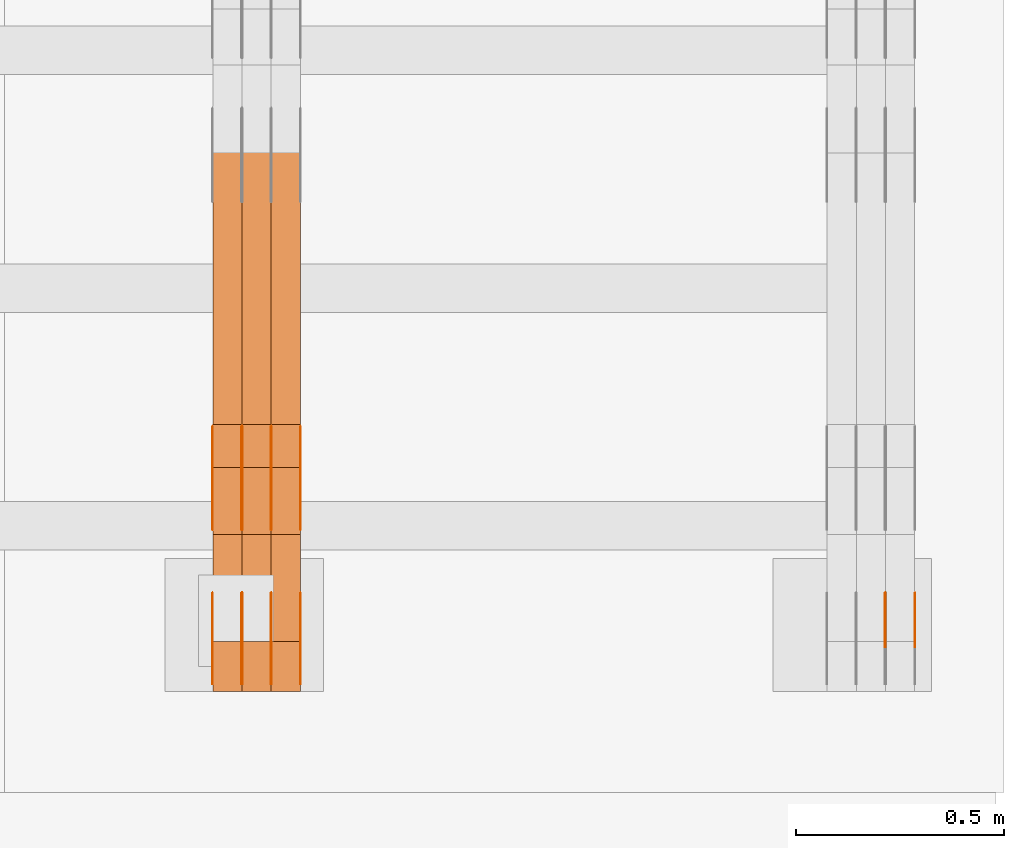
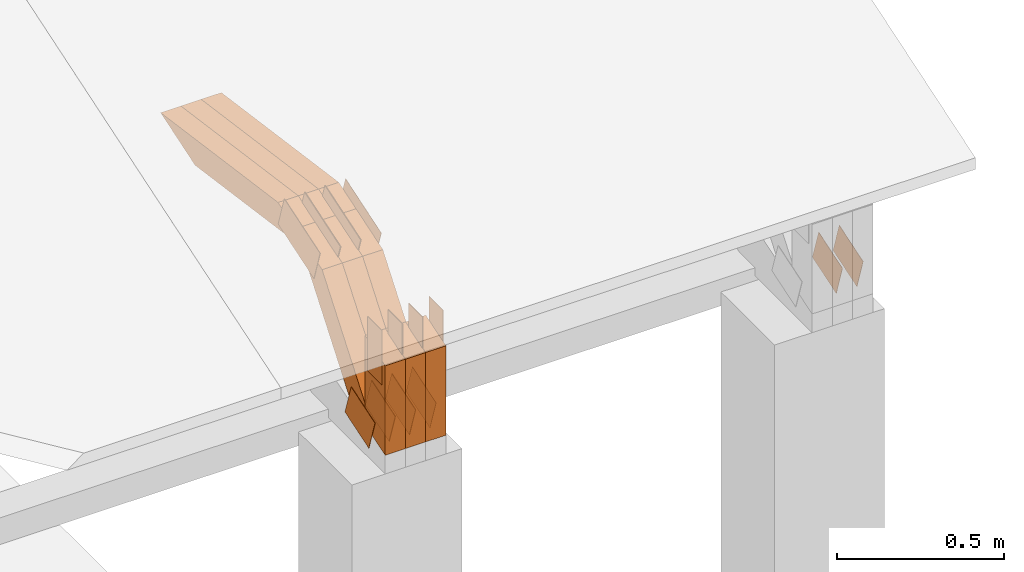
# One storey, part 306 of 385: 29 proxies.
"""IFC2X3 building model written with IfcOpenShell, lengths in millimetres."""

from ifc_helpers import new_model, entity, si_unit, converted_unit, derived_unit, direction, frame, frame_2d, origin, place, context, subcontext, project, spatial, polyline, rectangle, outline, extrude, source, transform, mapped, material, type_object, type_shapes, element, save


model = new_model("IFC2X3")

# Units and contexts
model_context = context("Model", 3, precision=0.01, world=origin(), true_north=direction((6.12303176911189e-17, 1.0)))
body_context = subcontext(model_context, "Body", "Model", "MODEL_VIEW")
ifc_project = project(units=[si_unit("LENGTHUNIT", "METRE", prefix="MILLI"), si_unit("AREAUNIT", "SQUARE_METRE"), si_unit("VOLUMEUNIT", "CUBIC_METRE"), converted_unit("PLANEANGLEUNIT", "DEGREE", entity("IfcRatioMeasure", 0.0174532925199433), si_unit("PLANEANGLEUNIT", "RADIAN"), dimensions=[0, 0, 0, 0, 0, 0, 0]), si_unit("MASSUNIT", "GRAM", prefix="KILO"), derived_unit("MASSDENSITYUNIT", [(si_unit("MASSUNIT", "GRAM", prefix="KILO"), 1), (si_unit("LENGTHUNIT", "METRE"), -3)]), si_unit("TIMEUNIT", "SECOND"), si_unit("FREQUENCYUNIT", "HERTZ"), si_unit("THERMODYNAMICTEMPERATUREUNIT", "DEGREE_CELSIUS"), derived_unit("THERMALTRANSMITTANCEUNIT", [(si_unit("MASSUNIT", "GRAM", prefix="KILO"), 1), (si_unit("THERMODYNAMICTEMPERATUREUNIT", "KELVIN"), -1), (si_unit("TIMEUNIT", "SECOND"), -3)]), derived_unit("VOLUMETRICFLOWRATEUNIT", [(si_unit("LENGTHUNIT", "METRE"), 3), (si_unit("TIMEUNIT", "SECOND"), -1)]), si_unit("ELECTRICCURRENTUNIT", "AMPERE"), si_unit("ELECTRICVOLTAGEUNIT", "VOLT"), si_unit("POWERUNIT", "WATT"), si_unit("FORCEUNIT", "NEWTON", prefix="KILO"), si_unit("ILLUMINANCEUNIT", "LUX"), si_unit("LUMINOUSFLUXUNIT", "LUMEN"), si_unit("LUMINOUSINTENSITYUNIT", "CANDELA"), derived_unit("USERDEFINED", [(si_unit("MASSUNIT", "GRAM", prefix="KILO"), -1), (si_unit("LENGTHUNIT", "METRE"), -2), (si_unit("TIMEUNIT", "SECOND"), 3), (si_unit("LUMINOUSFLUXUNIT", "LUMEN"), 1)]), derived_unit("LINEARVELOCITYUNIT", [(si_unit("LENGTHUNIT", "METRE"), 1), (si_unit("TIMEUNIT", "SECOND"), -1)]), si_unit("PRESSUREUNIT", "PASCAL"), derived_unit("USERDEFINED", [(si_unit("LENGTHUNIT", "METRE"), -2), (si_unit("MASSUNIT", "GRAM", prefix="KILO"), 1), (si_unit("TIMEUNIT", "SECOND"), -2)])], contexts=[model_context])

# Site, building, storey
site_placement = place(None, origin())
site = spatial("IfcSite", under=ifc_project, at=site_placement, CompositionType="ELEMENT")
building_placement = place(site_placement, origin())
building = spatial("IfcBuilding", under=site, at=building_placement, CompositionType="ELEMENT")
storey_placement = place(building_placement, origin())
storey = spatial("IfcBuildingStorey", under=building, at=storey_placement, Name="Default", CompositionType="ELEMENT", Elevation=0.0)

# Proxies
ifc_material_1 = material(Name="IfcSurfaceStyle #615484")
building_element_proxy_type_1 = type_object("IfcBuildingElementProxyType", PredefinedType="NOTDEFINED", material=ifc_material_1)
shared_shape_1 = source(origin(), body_context, "Body", "SweptSolid", [
    extrude(outline(polyline([(-74.999865408764, -60.0000379172698), (74.9998729365771, -60.0000379172698), (74.9998642299588, 60.0000379172698), (-74.9998717577719, 60.0000379172698), (-74.999865408764, -60.0000379172698)])), frame((75.0005044383734, 60.0001679035349, 0.0), z_axis=(0.0, 0.0, 1.0), x_axis=(-1.0, 0.0, 0.0)), (0.0, 0.0, 1.0), 1.3),
])
type_shapes(building_element_proxy_type_1, [shared_shape_1])
proxy_1_placement = place(building_placement, frame((49861.3, 2998.66143710397, 150.423871180894), z_axis=(-1.0, 0.0, 0.0), x_axis=(0.0, 0.951056516295124, 0.309016994375039)))
element("IfcBuildingElementProxy", 1, at=proxy_1_placement, inside=storey, type_object=building_element_proxy_type_1, material=ifc_material_1, context=body_context, shape_type="MappedRepresentation", body=[
    mapped(shared_shape_1, transform((0.0, 0.0, 0.0), scale=1.0)),
])
ifc_material_2 = material(Name="IfcSurfaceStyle #615427")
building_element_proxy_type_2 = type_object("IfcBuildingElementProxyType", PredefinedType="NOTDEFINED", material=ifc_material_2)
shared_shape_2 = source(origin(), body_context, "Body", "SweptSolid", [
    extrude(outline(polyline([(-74.999865408764, -60.0000379172698), (74.9998729365771, -60.0000379172698), (74.9998642299588, 60.0000379172698), (-74.9998717577719, 60.0000379172698), (-74.999865408764, -60.0000379172698)])), frame((75.0005044383734, 60.0001679035349, 0.0), z_axis=(0.0, 0.0, 1.0), x_axis=(-1.0, 0.0, 0.0)), (0.0, 0.0, 1.0), 1.3),
])
type_shapes(building_element_proxy_type_2, [shared_shape_2])
proxy_2_placement = place(building_placement, frame((49790.0, 2998.66143710397, 150.423871180894), z_axis=(-1.0, 0.0, 0.0), x_axis=(0.0, 0.951056516295124, 0.309016994375039)))
element("IfcBuildingElementProxy", 2, at=proxy_2_placement, inside=storey, type_object=building_element_proxy_type_2, material=ifc_material_2, context=body_context, shape_type="MappedRepresentation", body=[
    mapped(shared_shape_2, transform((0.0, 0.0, 0.0), scale=1.0)),
])
ifc_material_3 = material(Name="IfcSurfaceStyle #581052")
building_element_proxy_type_3 = type_object("IfcBuildingElementProxyType", PredefinedType="NOTDEFINED", material=ifc_material_3)
shared_shape_3 = source(origin(), body_context, "Body", "SweptSolid", [
    extrude(outline(polyline([(-74.999865408764, -60.0000379172698), (74.9998729365771, -60.0000379172698), (74.9998642299588, 60.0000379172698), (-74.9998717577719, 60.0000379172698), (-74.999865408764, -60.0000379172698)])), frame((75.0005044383734, 60.0001679035349, 0.0), z_axis=(0.0, 0.0, 1.0), x_axis=(-1.0, 0.0, 0.0)), (0.0, 0.0, 1.0), 1.3),
])
type_shapes(building_element_proxy_type_3, [shared_shape_3])
proxy_3_placement = place(building_placement, frame((48386.3, 2998.66143710398, 150.423871180894), z_axis=(-1.0, 0.0, 0.0), x_axis=(0.0, 0.951056516295124, 0.309016994375039)))
element("IfcBuildingElementProxy", 3, at=proxy_3_placement, inside=storey, type_object=building_element_proxy_type_3, material=ifc_material_3, context=body_context, shape_type="MappedRepresentation", body=[
    mapped(shared_shape_3, transform((0.0, 0.0, 0.0), scale=1.0)),
])
ifc_material_4 = material(Name="IfcSurfaceStyle #580995")
building_element_proxy_type_4 = type_object("IfcBuildingElementProxyType", PredefinedType="NOTDEFINED", material=ifc_material_4)
shared_shape_4 = source(origin(), body_context, "Body", "SweptSolid", [
    extrude(outline(polyline([(-74.999865408764, -60.0000379172698), (74.9998729365771, -60.0000379172698), (74.9998642299588, 60.0000379172698), (-74.9998717577719, 60.0000379172698), (-74.999865408764, -60.0000379172698)])), frame((75.0005044383734, 60.0001679035349, 0.0), z_axis=(0.0, 0.0, 1.0), x_axis=(-1.0, 0.0, 0.0)), (0.0, 0.0, 1.0), 1.3),
])
type_shapes(building_element_proxy_type_4, [shared_shape_4])
proxy_4_placement = place(building_placement, frame((48315.0, 2998.66143710398, 150.423871180894), z_axis=(-1.0, 0.0, 0.0), x_axis=(0.0, 0.951056516295124, 0.309016994375039)))
element("IfcBuildingElementProxy", 4, at=proxy_4_placement, inside=storey, type_object=building_element_proxy_type_4, material=ifc_material_4, context=body_context, shape_type="MappedRepresentation", body=[
    mapped(shared_shape_4, transform((0.0, 0.0, 0.0), scale=1.0)),
])
ifc_material_5 = material(Name="IfcSurfaceStyle #580938")
building_element_proxy_type_5 = type_object("IfcBuildingElementProxyType", PredefinedType="NOTDEFINED", material=ifc_material_5)
shared_shape_5 = source(origin(), body_context, "Body", "SweptSolid", [
    extrude(outline(polyline([(-74.999865408764, -60.0000379172698), (74.9998729365771, -60.0000379172698), (74.9998642299588, 60.0000379172698), (-74.9998717577719, 60.0000379172698), (-74.999865408764, -60.0000379172698)])), frame((75.0005044383734, 60.0001679035349, 0.0), z_axis=(0.0, 0.0, 1.0), x_axis=(-1.0, 0.0, 0.0)), (0.0, 0.0, 1.0), 1.3),
])
type_shapes(building_element_proxy_type_5, [shared_shape_5])
proxy_5_placement = place(building_placement, frame((48316.3, 2998.66143710398, 150.423871180894), z_axis=(-1.0, 0.0, 0.0), x_axis=(0.0, 0.951056516295124, 0.309016994375039)))
element("IfcBuildingElementProxy", 5, at=proxy_5_placement, inside=storey, type_object=building_element_proxy_type_5, material=ifc_material_5, context=body_context, shape_type="MappedRepresentation", body=[
    mapped(shared_shape_5, transform((0.0, 0.0, 0.0), scale=1.0)),
])
ifc_material_6 = material(Name="IfcSurfaceStyle #580881")
building_element_proxy_type_6 = type_object("IfcBuildingElementProxyType", PredefinedType="NOTDEFINED", material=ifc_material_6)
shared_shape_6 = source(origin(), body_context, "Body", "SweptSolid", [
    extrude(outline(polyline([(-74.999865408764, -60.0000379172698), (74.9998729365771, -60.0000379172698), (74.9998642299588, 60.0000379172698), (-74.9998717577719, 60.0000379172698), (-74.999865408764, -60.0000379172698)])), frame((75.0005044383734, 60.0001679035349, 0.0), z_axis=(0.0, 0.0, 1.0), x_axis=(-1.0, 0.0, 0.0)), (0.0, 0.0, 1.0), 1.29999999999999),
])
type_shapes(building_element_proxy_type_6, [shared_shape_6])
proxy_6_placement = place(building_placement, frame((48245.0, 2998.66143710398, 150.423871180894), z_axis=(-1.0, 0.0, 0.0), x_axis=(0.0, 0.951056516295124, 0.309016994375039)))
element("IfcBuildingElementProxy", 6, at=proxy_6_placement, inside=storey, type_object=building_element_proxy_type_6, material=ifc_material_6, context=body_context, shape_type="MappedRepresentation", body=[
    mapped(shared_shape_6, transform((0.0, 0.0, 0.0), scale=1.0)),
])
ifc_material_7 = material(Name="IfcSurfaceStyle #580824")
building_element_proxy_type_7 = type_object("IfcBuildingElementProxyType", PredefinedType="NOTDEFINED", material=ifc_material_7)
shared_shape_7 = source(origin(), body_context, "Body", "SweptSolid", [
    extrude(outline(polyline([(-74.999865408764, -60.0000379172698), (74.9998729365771, -60.0000379172698), (74.9998642299588, 60.0000379172698), (-74.9998717577719, 60.0000379172698), (-74.999865408764, -60.0000379172698)])), frame((75.0005044383734, 60.0001679035349, 0.0), z_axis=(0.0, 0.0, 1.0), x_axis=(-1.0, 0.0, 0.0)), (0.0, 0.0, 1.0), 1.29999999999999),
])
type_shapes(building_element_proxy_type_7, [shared_shape_7])
proxy_7_placement = place(building_placement, frame((48246.3, 2998.66143710398, 150.423871180894), z_axis=(-1.0, 0.0, 0.0), x_axis=(0.0, 0.951056516295124, 0.309016994375039)))
element("IfcBuildingElementProxy", 7, at=proxy_7_placement, inside=storey, type_object=building_element_proxy_type_7, material=ifc_material_7, context=body_context, shape_type="MappedRepresentation", body=[
    mapped(shared_shape_7, transform((0.0, 0.0, 0.0), scale=1.0)),
])
ifc_material_8 = material(Name="IfcSurfaceStyle #580767")
building_element_proxy_type_8 = type_object("IfcBuildingElementProxyType", PredefinedType="NOTDEFINED", material=ifc_material_8)
shared_shape_8 = source(origin(), body_context, "Body", "SweptSolid", [
    extrude(outline(polyline([(-74.999865408764, -60.0000379172698), (74.9998729365771, -60.0000379172698), (74.9998642299588, 60.0000379172698), (-74.9998717577719, 60.0000379172698), (-74.999865408764, -60.0000379172698)])), frame((75.0005044383734, 60.0001679035349, 0.0), z_axis=(0.0, 0.0, 1.0), x_axis=(-1.0, 0.0, 0.0)), (0.0, 0.0, 1.0), 1.29999999999999),
])
type_shapes(building_element_proxy_type_8, [shared_shape_8])
proxy_8_placement = place(building_placement, frame((48175.0, 2998.66143710398, 150.423871180894), z_axis=(-1.0, 0.0, 0.0), x_axis=(0.0, 0.951056516295124, 0.309016994375039)))
element("IfcBuildingElementProxy", 8, at=proxy_8_placement, inside=storey, type_object=building_element_proxy_type_8, material=ifc_material_8, context=body_context, shape_type="MappedRepresentation", body=[
    mapped(shared_shape_8, transform((0.0, 0.0, 0.0), scale=1.0)),
])
ifc_material_9 = material(Name="IfcSurfaceStyle #572502")
building_element_proxy_type_9 = type_object("IfcBuildingElementProxyType", PredefinedType="NOTDEFINED", material=ifc_material_9)
shared_shape_9 = source(origin(), body_context, "Body", "SweptSolid", [
    extrude(outline(polyline([(-112.500266735783, -59.9999130784581), (112.500275442392, -59.9999130784581), (112.500262020557, 59.9999130784582), (-112.500270727166, 59.9999130784581), (-112.500266735783, -59.9999130784581)])), frame((112.500275442392, 60.0001020984692, 0.0), z_axis=(0.0, 0.0, 1.0), x_axis=(-1.0, 0.0, 0.0)), (0.0, 0.0, 1.0), 1.3),
])
type_shapes(building_element_proxy_type_9, [shared_shape_9])
proxy_9_placement = place(building_placement, frame((48386.3, 3327.32420598509, 571.284602786019), z_axis=(-1.0, 0.0, 0.0), x_axis=(0.0, 0.951056516295154, 0.309016994374948)))
element("IfcBuildingElementProxy", 9, at=proxy_9_placement, inside=storey, type_object=building_element_proxy_type_9, material=ifc_material_9, context=body_context, shape_type="MappedRepresentation", body=[
    mapped(shared_shape_9, transform((0.0, 0.0, 0.0), scale=1.0)),
])
ifc_material_10 = material(Name="IfcSurfaceStyle #572445")
building_element_proxy_type_10 = type_object("IfcBuildingElementProxyType", PredefinedType="NOTDEFINED", material=ifc_material_10)
shared_shape_10 = source(origin(), body_context, "Body", "SweptSolid", [
    extrude(outline(polyline([(-112.500266735783, -59.9999130784581), (112.500275442392, -59.9999130784581), (112.500262020557, 59.9999130784582), (-112.500270727166, 59.9999130784581), (-112.500266735783, -59.9999130784581)])), frame((112.500275442392, 60.0001020984692, 0.0), z_axis=(0.0, 0.0, 1.0), x_axis=(-1.0, 0.0, 0.0)), (0.0, 0.0, 1.0), 1.3),
])
type_shapes(building_element_proxy_type_10, [shared_shape_10])
proxy_10_placement = place(building_placement, frame((48315.0, 3327.32420598509, 571.284602786019), z_axis=(-1.0, 0.0, 0.0), x_axis=(0.0, 0.951056516295154, 0.309016994374948)))
element("IfcBuildingElementProxy", 10, at=proxy_10_placement, inside=storey, type_object=building_element_proxy_type_10, material=ifc_material_10, context=body_context, shape_type="MappedRepresentation", body=[
    mapped(shared_shape_10, transform((0.0, 0.0, 0.0), scale=1.0)),
])
ifc_material_11 = material(Name="IfcSurfaceStyle #572388")
building_element_proxy_type_11 = type_object("IfcBuildingElementProxyType", PredefinedType="NOTDEFINED", material=ifc_material_11)
shared_shape_11 = source(origin(), body_context, "Body", "SweptSolid", [
    extrude(outline(polyline([(-112.500266735783, -59.9999130784581), (112.500275442392, -59.9999130784581), (112.500262020557, 59.9999130784582), (-112.500270727166, 59.9999130784581), (-112.500266735783, -59.9999130784581)])), frame((112.500275442392, 60.0001020984692, 0.0), z_axis=(0.0, 0.0, 1.0), x_axis=(-1.0, 0.0, 0.0)), (0.0, 0.0, 1.0), 1.3),
])
type_shapes(building_element_proxy_type_11, [shared_shape_11])
proxy_11_placement = place(building_placement, frame((48316.3, 3327.32420598509, 571.284602786019), z_axis=(-1.0, 0.0, 0.0), x_axis=(0.0, 0.951056516295154, 0.309016994374948)))
element("IfcBuildingElementProxy", 11, at=proxy_11_placement, inside=storey, type_object=building_element_proxy_type_11, material=ifc_material_11, context=body_context, shape_type="MappedRepresentation", body=[
    mapped(shared_shape_11, transform((0.0, 0.0, 0.0), scale=1.0)),
])
ifc_material_12 = material(Name="IfcSurfaceStyle #572331")
building_element_proxy_type_12 = type_object("IfcBuildingElementProxyType", PredefinedType="NOTDEFINED", material=ifc_material_12)
shared_shape_12 = source(origin(), body_context, "Body", "SweptSolid", [
    extrude(outline(polyline([(-112.500266735783, -59.9999130784581), (112.500275442392, -59.9999130784581), (112.500262020557, 59.9999130784582), (-112.500270727166, 59.9999130784581), (-112.500266735783, -59.9999130784581)])), frame((112.500275442392, 60.0001020984692, 0.0), z_axis=(0.0, 0.0, 1.0), x_axis=(-1.0, 0.0, 0.0)), (0.0, 0.0, 1.0), 1.29999999999998),
])
type_shapes(building_element_proxy_type_12, [shared_shape_12])
proxy_12_placement = place(building_placement, frame((48245.0, 3327.32420598509, 571.284602786019), z_axis=(-1.0, 0.0, 0.0), x_axis=(0.0, 0.951056516295154, 0.309016994374948)))
element("IfcBuildingElementProxy", 12, at=proxy_12_placement, inside=storey, type_object=building_element_proxy_type_12, material=ifc_material_12, context=body_context, shape_type="MappedRepresentation", body=[
    mapped(shared_shape_12, transform((0.0, 0.0, 0.0), scale=1.0)),
])
ifc_material_13 = material(Name="IfcSurfaceStyle #572274")
building_element_proxy_type_13 = type_object("IfcBuildingElementProxyType", PredefinedType="NOTDEFINED", material=ifc_material_13)
shared_shape_13 = source(origin(), body_context, "Body", "SweptSolid", [
    extrude(outline(polyline([(-112.500266735783, -59.9999130784581), (112.500275442392, -59.9999130784581), (112.500262020557, 59.9999130784582), (-112.500270727166, 59.9999130784581), (-112.500266735783, -59.9999130784581)])), frame((112.500275442392, 60.0001020984692, 0.0), z_axis=(0.0, 0.0, 1.0), x_axis=(-1.0, 0.0, 0.0)), (0.0, 0.0, 1.0), 1.29999999999998),
])
type_shapes(building_element_proxy_type_13, [shared_shape_13])
proxy_13_placement = place(building_placement, frame((48246.3, 3327.32420598509, 571.284602786019), z_axis=(-1.0, 0.0, 0.0), x_axis=(0.0, 0.951056516295154, 0.309016994374948)))
element("IfcBuildingElementProxy", 13, at=proxy_13_placement, inside=storey, type_object=building_element_proxy_type_13, material=ifc_material_13, context=body_context, shape_type="MappedRepresentation", body=[
    mapped(shared_shape_13, transform((0.0, 0.0, 0.0), scale=1.0)),
])
ifc_material_14 = material(Name="IfcSurfaceStyle #572217")
building_element_proxy_type_14 = type_object("IfcBuildingElementProxyType", PredefinedType="NOTDEFINED", material=ifc_material_14)
shared_shape_14 = source(origin(), body_context, "Body", "SweptSolid", [
    extrude(outline(polyline([(-112.500266735783, -59.9999130784581), (112.500275442392, -59.9999130784581), (112.500262020557, 59.9999130784582), (-112.500270727166, 59.9999130784581), (-112.500266735783, -59.9999130784581)])), frame((112.500275442392, 60.0001020984692, 0.0), z_axis=(0.0, 0.0, 1.0), x_axis=(-1.0, 0.0, 0.0)), (0.0, 0.0, 1.0), 1.29999999999999),
])
type_shapes(building_element_proxy_type_14, [shared_shape_14])
proxy_14_placement = place(building_placement, frame((48175.0, 3327.32420598509, 571.284602786019), z_axis=(-1.0, 0.0, 0.0), x_axis=(0.0, 0.951056516295154, 0.309016994374948)))
element("IfcBuildingElementProxy", 14, at=proxy_14_placement, inside=storey, type_object=building_element_proxy_type_14, material=ifc_material_14, context=body_context, shape_type="MappedRepresentation", body=[
    mapped(shared_shape_14, transform((0.0, 0.0, 0.0), scale=1.0)),
])
ifc_material_15 = material(Name="IfcSurfaceStyle #571476")
building_element_proxy_type_15 = type_object("IfcBuildingElementProxyType", PredefinedType="NOTDEFINED", material=ifc_material_15)
shared_shape_15 = source(origin(), body_context, "Body", "SweptSolid", [
    extrude(rectangle(XDim=199.999969482422, YDim=84.0, at=frame_2d((1.4210854715202e-14, 0.0), x_axis=(1.0, 0.0))), frame((100.000010815955, 42.0, 0.0), z_axis=(0.0, 0.0, 1.0), x_axis=(-1.0, 0.0, 0.0)), (0.0, 0.0, 1.0), 1.3),
])
type_shapes(building_element_proxy_type_15, [shared_shape_15])
proxy_15_placement = place(building_placement, frame((48386.3, 3042.0, 514.460048047401), z_axis=(-1.0, 0.0, 0.0), x_axis=(0.0, 0.0, -1.0)))
element("IfcBuildingElementProxy", 15, at=proxy_15_placement, inside=storey, type_object=building_element_proxy_type_15, material=ifc_material_15, context=body_context, shape_type="MappedRepresentation", body=[
    mapped(shared_shape_15, transform((0.0, 0.0, 0.0), scale=1.0)),
])
ifc_material_16 = material(Name="IfcSurfaceStyle #571419")
building_element_proxy_type_16 = type_object("IfcBuildingElementProxyType", PredefinedType="NOTDEFINED", material=ifc_material_16)
shared_shape_16 = source(origin(), body_context, "Body", "SweptSolid", [
    extrude(rectangle(XDim=199.999969482422, YDim=84.0, at=frame_2d((1.4210854715202e-14, 0.0), x_axis=(1.0, 0.0))), frame((100.000010815955, 42.0, 0.0), z_axis=(0.0, 0.0, 1.0), x_axis=(-1.0, 0.0, 0.0)), (0.0, 0.0, 1.0), 1.3),
])
type_shapes(building_element_proxy_type_16, [shared_shape_16])
proxy_16_placement = place(building_placement, frame((48315.0, 3042.0, 514.460048047401), z_axis=(-1.0, 0.0, 0.0), x_axis=(0.0, 0.0, -1.0)))
element("IfcBuildingElementProxy", 16, at=proxy_16_placement, inside=storey, type_object=building_element_proxy_type_16, material=ifc_material_16, context=body_context, shape_type="MappedRepresentation", body=[
    mapped(shared_shape_16, transform((0.0, 0.0, 0.0), scale=1.0)),
])
ifc_material_17 = material(Name="IfcSurfaceStyle #571362")
building_element_proxy_type_17 = type_object("IfcBuildingElementProxyType", PredefinedType="NOTDEFINED", material=ifc_material_17)
shared_shape_17 = source(origin(), body_context, "Body", "SweptSolid", [
    extrude(rectangle(XDim=199.999969482422, YDim=84.0, at=frame_2d((1.4210854715202e-14, 0.0), x_axis=(1.0, 0.0))), frame((100.000010815955, 42.0, 0.0), z_axis=(0.0, 0.0, 1.0), x_axis=(-1.0, 0.0, 0.0)), (0.0, 0.0, 1.0), 1.3),
])
type_shapes(building_element_proxy_type_17, [shared_shape_17])
proxy_17_placement = place(building_placement, frame((48316.3, 3042.0, 514.460048047401), z_axis=(-1.0, 0.0, 0.0), x_axis=(0.0, 0.0, -1.0)))
element("IfcBuildingElementProxy", 17, at=proxy_17_placement, inside=storey, type_object=building_element_proxy_type_17, material=ifc_material_17, context=body_context, shape_type="MappedRepresentation", body=[
    mapped(shared_shape_17, transform((0.0, 0.0, 0.0), scale=1.0)),
])
ifc_material_18 = material(Name="IfcSurfaceStyle #571305")
building_element_proxy_type_18 = type_object("IfcBuildingElementProxyType", PredefinedType="NOTDEFINED", material=ifc_material_18)
shared_shape_18 = source(origin(), body_context, "Body", "SweptSolid", [
    extrude(rectangle(XDim=199.999969482422, YDim=84.0, at=frame_2d((1.4210854715202e-14, 0.0), x_axis=(1.0, 0.0))), frame((100.000010815955, 42.0, 0.0), z_axis=(0.0, 0.0, 1.0), x_axis=(-1.0, 0.0, 0.0)), (0.0, 0.0, 1.0), 1.29999999999998),
])
type_shapes(building_element_proxy_type_18, [shared_shape_18])
proxy_18_placement = place(building_placement, frame((48245.0, 3042.0, 514.460048047401), z_axis=(-1.0, 0.0, 0.0), x_axis=(0.0, 0.0, -1.0)))
element("IfcBuildingElementProxy", 18, at=proxy_18_placement, inside=storey, type_object=building_element_proxy_type_18, material=ifc_material_18, context=body_context, shape_type="MappedRepresentation", body=[
    mapped(shared_shape_18, transform((0.0, 0.0, 0.0), scale=1.0)),
])
ifc_material_19 = material(Name="IfcSurfaceStyle #571248")
building_element_proxy_type_19 = type_object("IfcBuildingElementProxyType", PredefinedType="NOTDEFINED", material=ifc_material_19)
shared_shape_19 = source(origin(), body_context, "Body", "SweptSolid", [
    extrude(rectangle(XDim=199.999969482422, YDim=84.0, at=frame_2d((1.4210854715202e-14, 0.0), x_axis=(1.0, 0.0))), frame((100.000010815955, 42.0, 0.0), z_axis=(0.0, 0.0, 1.0), x_axis=(-1.0, 0.0, 0.0)), (0.0, 0.0, 1.0), 1.29999999999998),
])
type_shapes(building_element_proxy_type_19, [shared_shape_19])
proxy_19_placement = place(building_placement, frame((48246.3, 3042.0, 514.460048047401), z_axis=(-1.0, 0.0, 0.0), x_axis=(0.0, 0.0, -1.0)))
element("IfcBuildingElementProxy", 19, at=proxy_19_placement, inside=storey, type_object=building_element_proxy_type_19, material=ifc_material_19, context=body_context, shape_type="MappedRepresentation", body=[
    mapped(shared_shape_19, transform((0.0, 0.0, 0.0), scale=1.0)),
])
ifc_material_20 = material(Name="IfcSurfaceStyle #571191")
building_element_proxy_type_20 = type_object("IfcBuildingElementProxyType", PredefinedType="NOTDEFINED", material=ifc_material_20)
shared_shape_20 = source(origin(), body_context, "Body", "SweptSolid", [
    extrude(rectangle(XDim=199.999969482422, YDim=84.0, at=frame_2d((1.4210854715202e-14, 0.0), x_axis=(1.0, 0.0))), frame((100.000010815955, 42.0, 0.0), z_axis=(0.0, 0.0, 1.0), x_axis=(-1.0, 0.0, 0.0)), (0.0, 0.0, 1.0), 1.29999999999999),
])
type_shapes(building_element_proxy_type_20, [shared_shape_20])
proxy_20_placement = place(building_placement, frame((48175.0, 3042.0, 514.460048047401), z_axis=(-1.0, 0.0, 0.0), x_axis=(0.0, 0.0, -1.0)))
element("IfcBuildingElementProxy", 20, at=proxy_20_placement, inside=storey, type_object=building_element_proxy_type_20, material=ifc_material_20, context=body_context, shape_type="MappedRepresentation", body=[
    mapped(shared_shape_20, transform((0.0, 0.0, 0.0), scale=1.0)),
])
ifc_material_21 = material(Name="IfcSurfaceStyle #560208")
building_element_proxy_type_21 = type_object("IfcBuildingElementProxyType", Name="T1-W3 560206", PredefinedType="NOTDEFINED", material=ifc_material_21)
shared_shape_21 = source(origin(), body_context, "Body", "SweptSolid", [
    extrude(outline(polyline([(-314.232579911788, -47.5000200125938), (325.164873061766, -47.5000200125938), (297.999869081008, 6.48085173424295e-05), (200.434027234171, 47.4999876083351), (-509.366189465157, 47.4999876083352), (-314.232579911788, -47.5000200125938)])), frame((325.164873061766, 47.5001564752191, 0.0), z_axis=(0.0, 0.0, 1.0), x_axis=(-1.0, 0.0, 0.0)), (0.0, 0.0, 1.0), 70.0),
])
type_shapes(building_element_proxy_type_21, [shared_shape_21])
proxy_21_placement = place(building_placement, frame((48385.0, 3457.43747924876, 620.49890325051), z_axis=(-1.0, 0.0, 0.0), x_axis=(0.0, 0.990367219823621, -0.138465771578512)))
element("IfcBuildingElementProxy", 21, at=proxy_21_placement, inside=storey, type_object=building_element_proxy_type_21, material=ifc_material_21, Name="T1-W3", context=body_context, shape_type="MappedRepresentation", body=[
    mapped(shared_shape_21, transform((0.0, 0.0, 0.0), scale=1.0)),
])
ifc_material_22 = material(Name="IfcSurfaceStyle #560142")
building_element_proxy_type_22 = type_object("IfcBuildingElementProxyType", Name="T1-W3 560140", PredefinedType="NOTDEFINED", material=ifc_material_22)
shared_shape_22 = source(origin(), body_context, "Body", "SweptSolid", [
    extrude(outline(polyline([(-314.232579911788, -47.5000200125938), (325.164873061766, -47.5000200125938), (297.999869081008, 6.48085173424295e-05), (200.434027234171, 47.4999876083351), (-509.366189465157, 47.4999876083352), (-314.232579911788, -47.5000200125938)])), frame((325.164873061766, 47.5001564752191, 0.0), z_axis=(0.0, 0.0, 1.0), x_axis=(-1.0, 0.0, 0.0)), (0.0, 0.0, 1.0), 70.0),
])
type_shapes(building_element_proxy_type_22, [shared_shape_22])
proxy_22_placement = place(building_placement, frame((48315.0, 3457.43747924876, 620.49890325051), z_axis=(-1.0, 0.0, 0.0), x_axis=(0.0, 0.990367219823621, -0.138465771578512)))
element("IfcBuildingElementProxy", 22, at=proxy_22_placement, inside=storey, type_object=building_element_proxy_type_22, material=ifc_material_22, Name="T1-W3", context=body_context, shape_type="MappedRepresentation", body=[
    mapped(shared_shape_22, transform((0.0, 0.0, 0.0), scale=1.0)),
])
ifc_material_23 = material(Name="IfcSurfaceStyle #560076")
building_element_proxy_type_23 = type_object("IfcBuildingElementProxyType", Name="T1-W3 560074", PredefinedType="NOTDEFINED", material=ifc_material_23)
shared_shape_23 = source(origin(), body_context, "Body", "SweptSolid", [
    extrude(outline(polyline([(-314.232579911788, -47.5000200125938), (325.164873061766, -47.5000200125938), (297.999869081008, 6.48085173424295e-05), (200.434027234171, 47.4999876083351), (-509.366189465157, 47.4999876083352), (-314.232579911788, -47.5000200125938)])), frame((325.164873061766, 47.5001564752191, 0.0), z_axis=(0.0, 0.0, 1.0), x_axis=(-1.0, 0.0, 0.0)), (0.0, 0.0, 1.0), 70.0),
])
type_shapes(building_element_proxy_type_23, [shared_shape_23])
proxy_23_placement = place(building_placement, frame((48245.0, 3457.43747924876, 620.49890325051), z_axis=(-1.0, 0.0, 0.0), x_axis=(0.0, 0.990367219823621, -0.138465771578512)))
element("IfcBuildingElementProxy", 23, at=proxy_23_placement, inside=storey, type_object=building_element_proxy_type_23, material=ifc_material_23, Name="T1-W3", context=body_context, shape_type="MappedRepresentation", body=[
    mapped(shared_shape_23, transform((0.0, 0.0, 0.0), scale=1.0)),
])
ifc_material_24 = material(Name="IfcSurfaceStyle #559812")
building_element_proxy_type_24 = type_object("IfcBuildingElementProxyType", Name="T1-W14 559810", PredefinedType="NOTDEFINED", material=ifc_material_24)
shared_shape_24 = source(origin(), body_context, "Body", "SweptSolid", [
    extrude(outline(polyline([(-374.484689776928, -47.499919737532), (177.199556189275, -47.499919737532), (246.893257937645, -5.36774925340877e-05), (185.487930694801, 47.4999465762783), (-235.096055044793, 47.4999465762784), (-374.484689776928, -47.499919737532)])), frame((246.893257937645, 47.5000959779252, 0.0), z_axis=(0.0, 0.0, 1.0), x_axis=(-1.0, 0.0, 0.0)), (0.0, 0.0, 1.0), 70.0),
])
type_shapes(building_element_proxy_type_24, [shared_shape_24])
proxy_24_placement = place(building_placement, frame((48385.0, 3022.42877773025, 136.329406512195), z_axis=(-1.0, 0.0, 0.0), x_axis=(0.0, 0.611854146609475, 0.790970608352037)))
element("IfcBuildingElementProxy", 24, at=proxy_24_placement, inside=storey, type_object=building_element_proxy_type_24, material=ifc_material_24, Name="T1-W14", context=body_context, shape_type="MappedRepresentation", body=[
    mapped(shared_shape_24, transform((0.0, 0.0, 0.0), scale=1.0)),
])
ifc_material_25 = material(Name="IfcSurfaceStyle #559746")
building_element_proxy_type_25 = type_object("IfcBuildingElementProxyType", Name="T1-W14 559744", PredefinedType="NOTDEFINED", material=ifc_material_25)
shared_shape_25 = source(origin(), body_context, "Body", "SweptSolid", [
    extrude(outline(polyline([(-374.484689776928, -47.499919737532), (177.199556189275, -47.499919737532), (246.893257937645, -5.36774925340877e-05), (185.487930694801, 47.4999465762783), (-235.096055044793, 47.4999465762784), (-374.484689776928, -47.499919737532)])), frame((246.893257937645, 47.5000959779252, 0.0), z_axis=(0.0, 0.0, 1.0), x_axis=(-1.0, 0.0, 0.0)), (0.0, 0.0, 1.0), 70.0),
])
type_shapes(building_element_proxy_type_25, [shared_shape_25])
proxy_25_placement = place(building_placement, frame((48315.0, 3022.42877773025, 136.329406512195), z_axis=(-1.0, 0.0, 0.0), x_axis=(0.0, 0.611854146609475, 0.790970608352037)))
element("IfcBuildingElementProxy", 25, at=proxy_25_placement, inside=storey, type_object=building_element_proxy_type_25, material=ifc_material_25, Name="T1-W14", context=body_context, shape_type="MappedRepresentation", body=[
    mapped(shared_shape_25, transform((0.0, 0.0, 0.0), scale=1.0)),
])
ifc_material_26 = material(Name="IfcSurfaceStyle #559680")
building_element_proxy_type_26 = type_object("IfcBuildingElementProxyType", Name="T1-W14 559678", PredefinedType="NOTDEFINED", material=ifc_material_26)
shared_shape_26 = source(origin(), body_context, "Body", "SweptSolid", [
    extrude(outline(polyline([(-374.484689776928, -47.499919737532), (177.199556189275, -47.499919737532), (246.893257937645, -5.36774925340877e-05), (185.487930694801, 47.4999465762783), (-235.096055044793, 47.4999465762784), (-374.484689776928, -47.499919737532)])), frame((246.893257937645, 47.5000959779252, 0.0), z_axis=(0.0, 0.0, 1.0), x_axis=(-1.0, 0.0, 0.0)), (0.0, 0.0, 1.0), 70.0),
])
type_shapes(building_element_proxy_type_26, [shared_shape_26])
proxy_26_placement = place(building_placement, frame((48245.0, 3022.42877773025, 136.329406512195), z_axis=(-1.0, 0.0, 0.0), x_axis=(0.0, 0.611854146609475, 0.790970608352037)))
element("IfcBuildingElementProxy", 26, at=proxy_26_placement, inside=storey, type_object=building_element_proxy_type_26, material=ifc_material_26, Name="T1-W14", context=body_context, shape_type="MappedRepresentation", body=[
    mapped(shared_shape_26, transform((0.0, 0.0, 0.0), scale=1.0)),
])
ifc_material_27 = material(Name="IfcSurfaceStyle #559614")
building_element_proxy_type_27 = type_object("IfcBuildingElementProxyType", Name="T1-E3 559612", PredefinedType="NOTDEFINED", material=ifc_material_27)
shared_shape_27 = source(origin(), body_context, "Body", "SweptSolid", [
    extrude(outline(polyline([(-182.839673995971, -60.0), (143.849313735962, -60.0), (182.839677810669, 60.0), (-143.84931755066, 60.0), (-182.839673995971, -60.0)])), frame((182.839677810669, 60.0, 0.0), z_axis=(0.0, 0.0, 1.0), x_axis=(-1.0, 0.0, 0.0)), (0.0, 0.0, 1.0), 70.0),
])
type_shapes(building_element_proxy_type_27, [shared_shape_27])
proxy_27_placement = place(building_placement, frame((48385.0, 2940.0, 68.27587890625), z_axis=(-1.0, 0.0, 0.0), x_axis=(0.0, 0.0, 1.0)))
element("IfcBuildingElementProxy", 27, at=proxy_27_placement, inside=storey, type_object=building_element_proxy_type_27, material=ifc_material_27, Name="T1-E3", context=body_context, shape_type="MappedRepresentation", body=[
    mapped(shared_shape_27, transform((0.0, 0.0, 0.0), scale=1.0)),
])
ifc_material_28 = material(Name="IfcSurfaceStyle #559557")
building_element_proxy_type_28 = type_object("IfcBuildingElementProxyType", Name="T1-E3 559555", PredefinedType="NOTDEFINED", material=ifc_material_28)
shared_shape_28 = source(origin(), body_context, "Body", "SweptSolid", [
    extrude(outline(polyline([(-182.839673995971, -60.0), (143.849313735962, -60.0), (182.839677810669, 60.0), (-143.84931755066, 60.0), (-182.839673995971, -60.0)])), frame((182.839677810669, 60.0, 0.0), z_axis=(0.0, 0.0, 1.0), x_axis=(-1.0, 0.0, 0.0)), (0.0, 0.0, 1.0), 70.0),
])
type_shapes(building_element_proxy_type_28, [shared_shape_28])
proxy_28_placement = place(building_placement, frame((48315.0, 2940.0, 68.27587890625), z_axis=(-1.0, 0.0, 0.0), x_axis=(0.0, 0.0, 1.0)))
element("IfcBuildingElementProxy", 28, at=proxy_28_placement, inside=storey, type_object=building_element_proxy_type_28, material=ifc_material_28, Name="T1-E3", context=body_context, shape_type="MappedRepresentation", body=[
    mapped(shared_shape_28, transform((0.0, 0.0, 0.0), scale=1.0)),
])
ifc_material_29 = material(Name="IfcSurfaceStyle #559500")
building_element_proxy_type_29 = type_object("IfcBuildingElementProxyType", Name="T1-E3 559498", PredefinedType="NOTDEFINED", material=ifc_material_29)
shared_shape_29 = source(origin(), body_context, "Body", "SweptSolid", [
    extrude(outline(polyline([(-182.839673995971, -60.0), (143.849313735962, -60.0), (182.839677810669, 60.0), (-143.84931755066, 60.0), (-182.839673995971, -60.0)])), frame((182.839677810669, 60.0, 0.0), z_axis=(0.0, 0.0, 1.0), x_axis=(-1.0, 0.0, 0.0)), (0.0, 0.0, 1.0), 70.0),
])
type_shapes(building_element_proxy_type_29, [shared_shape_29])
proxy_29_placement = place(building_placement, frame((48245.0, 2940.0, 68.27587890625), z_axis=(-1.0, 0.0, 0.0), x_axis=(0.0, 0.0, 1.0)))
element("IfcBuildingElementProxy", 29, at=proxy_29_placement, inside=storey, type_object=building_element_proxy_type_29, material=ifc_material_29, Name="T1-E3", context=body_context, shape_type="MappedRepresentation", body=[
    mapped(shared_shape_29, transform((0.0, 0.0, 0.0), scale=1.0)),
])

save(model, "model.ifc")
